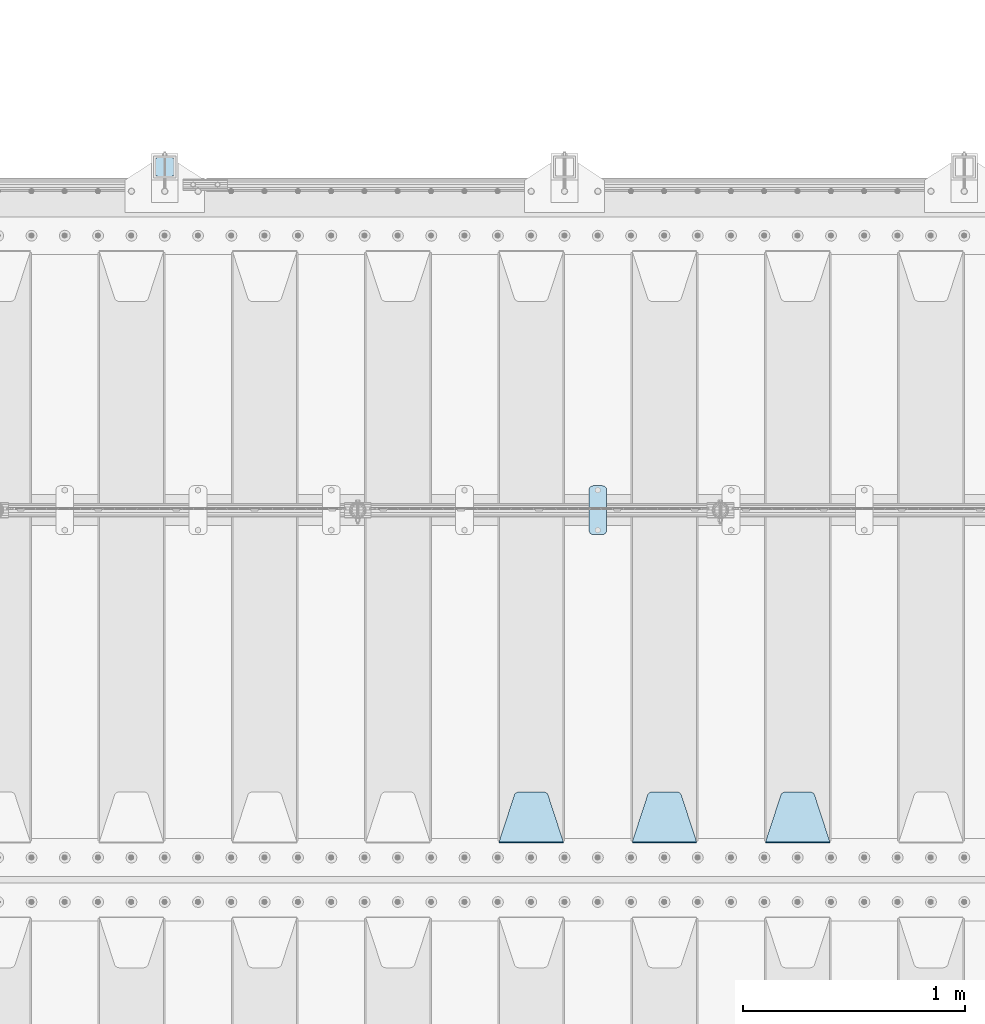
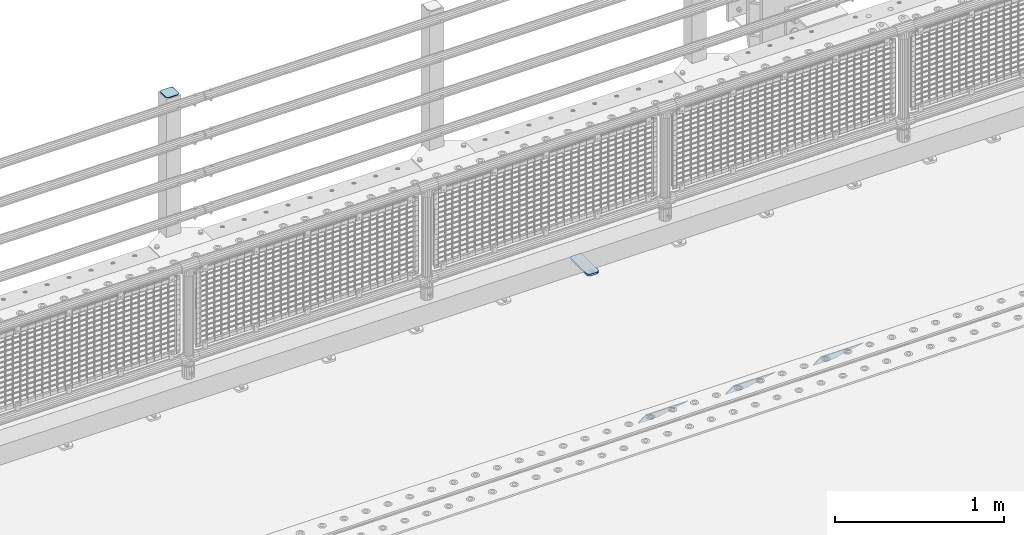
# One storey, part 213 of 242: 5 plates.
"""IFC2X3 building model written with IfcOpenShell, lengths in millimetres."""

from ifc_helpers import new_model, si_unit, frame, origin_with_axes, place, context, subcontext, project, spatial, faceted_brep, material, type_object, element, save


model = new_model("IFC2X3")

# Units and contexts
model_context = context("Model", 3, precision=1e-05, world=origin_with_axes())
body_context = subcontext(model_context, "Body", "Model", "MODEL_VIEW")
ifc_project = project(units=[si_unit("LENGTHUNIT", "METRE", prefix="MILLI"), si_unit("AREAUNIT", "SQUARE_METRE"), si_unit("VOLUMEUNIT", "CUBIC_METRE"), si_unit("MASSUNIT", "GRAM", prefix="KILO"), si_unit("TIMEUNIT", "SECOND"), si_unit("PLANEANGLEUNIT", "RADIAN"), si_unit("SOLIDANGLEUNIT", "STERADIAN"), si_unit("THERMODYNAMICTEMPERATUREUNIT", "DEGREE_CELSIUS"), si_unit("LUMINOUSINTENSITYUNIT", "LUMEN")], contexts=[model_context])

# Site, building, storey
site_placement = place(None, origin_with_axes())
site = spatial("IfcSite", under=ifc_project, at=site_placement, CompositionType="ELEMENT")
building_placement = place(site_placement, origin_with_axes())
building = spatial("IfcBuilding", under=site, at=building_placement, Name="Standard", CompositionType="ELEMENT")
storey_placement = place(building_placement, origin_with_axes())
storey = spatial("IfcBuildingStorey", under=building, at=storey_placement, Name="Undefined", CompositionType="ELEMENT", Elevation=0.0)

# Plates
ifc_material_1 = material(Name="STEEL/S355J2")
plate_type_1 = type_object("IfcPlateType", PredefinedType="NOTDEFINED")
plate_1_placement = place(storey_placement, frame((-30990.0, -19225.5, 21.0199999999977), z_axis=(1.0, 0.0, 0.0), x_axis=(0.0, -1.0, 0.0)))
element("IfcPlate", 1, at=plate_1_placement, inside=storey, type_object=plate_type_1, material=ifc_material_1, context=body_context, shape_type="Brep", body=[
    faceted_brep([(0.0, -7.0, 20.0), (0.0, -7.0, 60.0), (0.0, 7.0, 60.0), (0.0, 7.0, 20.0), (0.384294391937146, -7.0, 63.9018064403208), (0.384294391937146, 7.0, 63.9018064403208), (1.52240934977453, -7.0, 67.6536686473009), (1.52240934977453, 7.0, 67.6536686473009), (3.37060775395003, -7.0, 71.1114046603907), (3.37060775395003, 7.0, 71.1114046603907), (5.8578643762703, -7.0, 74.1421356237297), (5.8578643762703, 7.0, 74.1421356237297), (8.88859533960931, -7.0, 76.62939224605), (8.88859533960931, 7.0, 76.62939224605), (12.3463313526991, -7.0, 78.4775906502255), (12.3463313526991, 7.0, 78.4775906502255), (16.0981935596792, -7.0, 79.6157056080629), (16.0981935596792, 7.0, 79.6157056080629), (20.0, -7.0, 80.0), (20.0, 7.0, 80.0), (200.0, -7.0, 80.0), (200.0, 7.0, 80.0), (203.901806440321, -7.0, 79.6157056080629), (203.901806440321, 7.0, 79.6157056080629), (207.653668647301, -7.0, 78.4775906502255), (207.653668647301, 7.0, 78.4775906502255), (211.111404660391, -7.0, 76.62939224605), (211.111404660391, 7.0, 76.62939224605), (214.14213562373, -7.0, 74.1421356237297), (214.14213562373, 7.0, 74.1421356237297), (216.62939224605, -7.0, 71.1114046603907), (216.62939224605, 7.0, 71.1114046603907), (218.477590650225, -7.0, 67.6536686473009), (218.477590650225, 7.0, 67.6536686473009), (219.615705608063, -7.0, 63.9018064403208), (219.615705608063, 7.0, 63.9018064403208), (220.0, -7.0, 60.0), (220.0, 7.0, 60.0), (220.0, -7.0, 20.0), (220.0, 7.0, 20.0), (219.615705608063, -7.0, 16.0981935596792), (219.615705608063, 7.0, 16.0981935596792), (218.477590650225, -7.0, 12.3463313526991), (218.477590650225, 7.0, 12.3463313526991), (216.62939224605, -7.0, 8.88859533960931), (216.62939224605, 7.0, 8.88859533960931), (214.14213562373, -7.0, 5.8578643762703), (214.14213562373, 7.0, 5.8578643762703), (211.111404660391, -7.0, 3.37060775395003), (211.111404660391, 7.0, 3.37060775395003), (207.653668647301, -7.0, 1.52240934977453), (207.653668647301, 7.0, 1.52240934977453), (203.901806440321, -7.0, 0.384294391937146), (203.901806440321, 7.0, 0.384294391937146), (200.0, -7.0, 0.0), (200.0, 7.0, 0.0), (20.0, -7.0, 0.0), (20.0, 7.0, 0.0), (16.0981935596792, -7.0, 0.384294391937146), (16.0981935596792, 7.0, 0.384294391937146), (12.3463313526991, -7.0, 1.52240934977453), (12.3463313526991, 7.0, 1.52240934977453), (8.88859533960931, -7.0, 3.37060775395003), (8.88859533960931, 7.0, 3.37060775395003), (5.8578643762703, -7.0, 5.8578643762703), (5.8578643762703, 7.0, 5.8578643762703), (3.37060775395003, -7.0, 8.88859533960931), (3.37060775395003, 7.0, 8.88859533960931), (1.52240934977453, -7.0, 12.3463313526991), (1.52240934977453, 7.0, 12.3463313526991), (0.384294391937146, -7.0, 16.0981935596792), (0.384294391937146, 7.0, 16.0981935596792)], [[[0, 1, 2, 3]], [[1, 4, 5, 2]], [[4, 6, 7, 5]], [[6, 8, 9, 7]], [[8, 10, 11, 9]], [[10, 12, 13, 11]], [[12, 14, 15, 13]], [[14, 16, 17, 15]], [[16, 18, 19, 17]], [[18, 20, 21, 19]], [[20, 22, 23, 21]], [[22, 24, 25, 23]], [[24, 26, 27, 25]], [[26, 28, 29, 27]], [[28, 30, 31, 29]], [[30, 32, 33, 31]], [[32, 34, 35, 33]], [[34, 36, 37, 35]], [[36, 38, 39, 37]], [[38, 40, 41, 39]], [[40, 42, 43, 41]], [[42, 44, 45, 43]], [[44, 46, 47, 45]], [[46, 48, 49, 47]], [[48, 50, 51, 49]], [[50, 52, 53, 51]], [[52, 54, 55, 53]], [[54, 56, 57, 55]], [[56, 58, 59, 57]], [[58, 60, 61, 59]], [[60, 62, 63, 61]], [[62, 64, 65, 63]], [[64, 66, 67, 65]], [[66, 68, 69, 67]], [[68, 70, 71, 69]], [[70, 0, 3, 71]], [[5, 7, 9, 11, 13, 15, 17, 19, 21, 23, 25, 27, 29, 31, 33, 35, 37, 39, 41, 43, 45, 47, 49, 51, 53, 55, 57, 59, 61, 63, 65, 67, 69, 71, 3, 2]], [[70, 68, 66, 64, 62, 60, 58, 56, 54, 52, 50, 48, 46, 44, 42, 40, 38, 36, 34, 32, 30, 28, 26, 24, 22, 20, 18, 16, 14, 12, 10, 8, 6, 4, 1, 0]]]),
])
plate_type_2 = type_object("IfcPlateType", PredefinedType="NOTDEFINED")
plate_2_placement = place(storey_placement, frame((-32855.9999999999, -17833.9999999998, 1012.50000000001), z_axis=(0.0, 1.0, 0.0), x_axis=(-1.0, 0.0, 0.0)))
element("IfcPlate", 2, at=plate_2_placement, inside=storey, type_object=plate_type_2, material=ifc_material_1, context=body_context, shape_type="Brep", body=[
    faceted_brep([(0.0, -2.5, 19.0), (0.0, -2.5, 69.0), (0.0, 2.5, 69.0), (0.0, 2.5, 19.0), (0.476369668544066, -2.5, 73.2278977451715), (0.476369668544066, 2.5, 73.2278977451715), (1.88159150985302, -2.5, 77.2437910432345), (1.88159150985302, 2.5, 77.2437910432345), (4.14520183310742, -2.5, 80.8463062353148), (4.14520183310742, 2.5, 80.8463062353148), (7.15369376468516, -2.5, 83.8547981668926), (7.15369376468516, 2.5, 83.8547981668926), (10.7562089567655, -2.5, 86.118408490147), (10.7562089567655, 2.5, 86.118408490147), (14.7721022548285, -2.5, 87.5236303314559), (14.7721022548285, 2.5, 87.5236303314559), (19.0, -2.5, 88.0), (19.0, 2.5, 88.0), (69.0, -2.5, 88.0), (69.0, 2.5, 88.0), (73.2278977451715, -2.5, 87.5236303314559), (73.2278977451715, 2.5, 87.5236303314559), (77.2437910432345, -2.5, 86.118408490147), (77.2437910432345, 2.5, 86.118408490147), (80.8463062353148, -2.5, 83.8547981668926), (80.8463062353148, 2.5, 83.8547981668926), (83.8547981668926, -2.5, 80.8463062353148), (83.8547981668926, 2.5, 80.8463062353148), (86.118408490147, -2.5, 77.2437910432345), (86.118408490147, 2.5, 77.2437910432345), (87.5236303314559, -2.5, 73.2278977451715), (87.5236303314559, 2.5, 73.2278977451715), (88.0, -2.5, 69.0), (88.0, 2.5, 69.0), (88.0, -2.5, 19.0), (88.0, 2.5, 19.0), (87.5236303314559, -2.5, 14.7721022548285), (87.5236303314559, 2.5, 14.7721022548285), (86.118408490147, -2.5, 10.7562089567655), (86.118408490147, 2.5, 10.7562089567655), (83.8547981668926, -2.5, 7.15369376468516), (83.8547981668926, 2.5, 7.15369376468516), (80.8463062353148, -2.5, 4.14520183310742), (80.8463062353148, 2.5, 4.14520183310742), (77.2437910432345, -2.5, 1.88159150985302), (77.2437910432345, 2.5, 1.88159150985302), (73.2278977451715, -2.5, 0.476369668544066), (73.2278977451715, 2.5, 0.476369668544066), (69.0, -2.5, 0.0), (69.0, 2.5, 0.0), (19.0, -2.5, 0.0), (19.0, 2.5, 0.0), (14.7721022548285, -2.5, 0.476369668544066), (14.7721022548285, 2.5, 0.476369668544066), (10.7562089567655, -2.5, 1.88159150985302), (10.7562089567655, 2.5, 1.88159150985302), (7.15369376468516, -2.5, 4.14520183310742), (7.15369376468516, 2.5, 4.14520183310742), (4.14520183310742, -2.5, 7.15369376468516), (4.14520183310742, 2.5, 7.15369376468516), (1.88159150985302, -2.5, 10.7562089567655), (1.88159150985302, 2.5, 10.7562089567655), (0.476369668544066, -2.5, 14.7721022548285), (0.476369668544066, 2.5, 14.7721022548285)], [[[0, 1, 2, 3]], [[1, 4, 5, 2]], [[4, 6, 7, 5]], [[6, 8, 9, 7]], [[8, 10, 11, 9]], [[10, 12, 13, 11]], [[12, 14, 15, 13]], [[14, 16, 17, 15]], [[16, 18, 19, 17]], [[18, 20, 21, 19]], [[20, 22, 23, 21]], [[22, 24, 25, 23]], [[24, 26, 27, 25]], [[26, 28, 29, 27]], [[28, 30, 31, 29]], [[30, 32, 33, 31]], [[32, 34, 35, 33]], [[34, 36, 37, 35]], [[36, 38, 39, 37]], [[38, 40, 41, 39]], [[40, 42, 43, 41]], [[42, 44, 45, 43]], [[44, 46, 47, 45]], [[46, 48, 49, 47]], [[48, 50, 51, 49]], [[50, 52, 53, 51]], [[52, 54, 55, 53]], [[54, 56, 57, 55]], [[56, 58, 59, 57]], [[58, 60, 61, 59]], [[60, 62, 63, 61]], [[62, 0, 3, 63]], [[5, 7, 9, 11, 13, 15, 17, 19, 21, 23, 25, 27, 29, 31, 33, 35, 37, 39, 41, 43, 45, 47, 49, 51, 53, 55, 57, 59, 61, 63, 3, 2]], [[62, 60, 58, 56, 54, 52, 50, 48, 46, 44, 42, 40, 38, 36, 34, 32, 30, 28, 26, 24, 22, 20, 18, 16, 14, 12, 10, 8, 6, 4, 1, 0]]]),
])
ifc_material_2 = material(Name="STEEL/S355N")
plate_type_3 = type_object("IfcPlateType", PredefinedType="NOTDEFINED")
plate_3_placement = place(storey_placement, frame((-29905.0, -20831.767766953, -1.76776695296758), z_axis=(0.0, 0.707106781186547, -0.707106781186548), x_axis=(-1.0, 0.0, 0.0)))
element("IfcPlate", 3, at=plate_3_placement, inside=storey, type_object=plate_type_3, material=ifc_material_2, context=body_context, shape_type="Brep", body=[
    faceted_brep([(0.0, -2.5, 0.0), (69.345504679477, -2.50000000000182, 300.171731424829), (69.345504679477, 2.5, 300.171731424829), (0.0, 2.5, 0.0), (70.9274061199576, -2.5, 304.897442415398), (70.9274061199576, 2.5, 304.897442415398), (73.3818627772307, -2.5, 309.234538108525), (73.3818627772307, 2.50000000000182, 309.234538108529), (76.6187032999551, -2.5, 313.023683126101), (76.6187032999551, 2.50000000000182, 313.023683126103), (80.5190132704993, -2.5, 316.12567259537), (80.5190132704993, 2.5, 316.12567259537), (84.9395038596849, -2.5, 318.426546230474), (84.9395038596849, 2.50000000000182, 318.426546230476), (89.7177759439219, -2.49999999999818, 319.841774983273), (89.7177759439219, 2.50000000000182, 319.841774983273), (94.678286292652, -2.5, 320.319366455076), (94.678286292652, 2.5, 320.319366455076), (195.321713707348, -2.5, 320.319366455076), (195.321713707348, 2.5, 320.319366455076), (200.282224056078, -2.5, 319.841774983272), (200.282224056078, 2.50000000000182, 319.841774983273), (205.060496140315, -2.5, 318.426546230474), (205.060496140315, 2.49999999999818, 318.426546230474), (209.480986729501, -2.49999999999818, 316.12567259537), (209.480986729501, 2.5, 316.12567259537), (213.381296700045, -2.5, 313.023683126101), (213.381296700045, 2.49999999999818, 313.023683126101), (216.618137222769, -2.5, 309.234538108525), (216.618137222769, 2.5, 309.234538108523), (219.072593880042, -2.49999999999818, 304.897442415398), (219.072593880042, 2.50000000000182, 304.897442415398), (220.654495320523, -2.50000000000182, 300.171731424829), (220.654495320523, 2.5, 300.171731424829), (290.0, -2.5, 0.0), (290.0, 2.5, -1.81898940354586e-12)], [[[0, 1, 2, 3]], [[1, 4, 5, 2]], [[4, 6, 7, 5]], [[6, 8, 9, 7]], [[8, 10, 11, 9]], [[10, 12, 13, 11]], [[12, 14, 15, 13]], [[14, 16, 17, 15]], [[16, 18, 19, 17]], [[18, 20, 21, 19]], [[20, 22, 23, 21]], [[22, 24, 25, 23]], [[24, 26, 27, 25]], [[26, 28, 29, 27]], [[28, 30, 31, 29]], [[30, 32, 33, 31]], [[32, 34, 35, 33]], [[34, 0, 3, 35]], [[5, 7, 9, 11, 13, 15, 17, 19, 21, 23, 25, 27, 29, 31, 33, 35, 3, 2]], [[34, 32, 30, 28, 26, 24, 22, 20, 18, 16, 14, 12, 10, 8, 6, 4, 1, 0]]]),
])
plate_4_placement = place(storey_placement, frame((-30505.0, -20831.767766953, -1.76776695296758), z_axis=(0.0, 0.707106781186547, -0.707106781186548), x_axis=(-1.0, 0.0, 0.0)))
element("IfcPlate", 4, at=plate_4_placement, inside=storey, type_object=plate_type_3, material=ifc_material_2, context=body_context, shape_type="Brep", body=[
    faceted_brep([(0.0, -2.5, 0.0), (69.345504679477, -2.50000000000182, 300.171731424829), (69.345504679477, 2.5, 300.171731424829), (0.0, 2.5, 0.0), (70.9274061199576, -2.5, 304.897442415398), (70.9274061199576, 2.5, 304.897442415398), (73.3818627772307, -2.5, 309.234538108525), (73.3818627772307, 2.50000000000182, 309.234538108529), (76.6187032999551, -2.5, 313.023683126101), (76.6187032999551, 2.50000000000182, 313.023683126103), (80.5190132704993, -2.5, 316.12567259537), (80.5190132704993, 2.5, 316.12567259537), (84.9395038596849, -2.5, 318.426546230474), (84.9395038596849, 2.50000000000182, 318.426546230476), (89.7177759439219, -2.49999999999818, 319.841774983273), (89.7177759439219, 2.50000000000182, 319.841774983273), (94.678286292652, -2.5, 320.319366455076), (94.678286292652, 2.5, 320.319366455076), (195.321713707348, -2.5, 320.319366455076), (195.321713707348, 2.5, 320.319366455076), (200.282224056078, -2.5, 319.841774983272), (200.282224056078, 2.50000000000182, 319.841774983273), (205.060496140315, -2.5, 318.426546230474), (205.060496140315, 2.49999999999818, 318.426546230474), (209.480986729501, -2.49999999999818, 316.12567259537), (209.480986729501, 2.5, 316.12567259537), (213.381296700045, -2.5, 313.023683126101), (213.381296700045, 2.49999999999818, 313.023683126101), (216.618137222769, -2.5, 309.234538108525), (216.618137222769, 2.5, 309.234538108523), (219.072593880042, -2.49999999999818, 304.897442415398), (219.072593880042, 2.50000000000182, 304.897442415398), (220.654495320523, -2.50000000000182, 300.171731424829), (220.654495320523, 2.5, 300.171731424829), (290.0, -2.5, 0.0), (290.0, 2.5, -1.81898940354586e-12)], [[[0, 1, 2, 3]], [[1, 4, 5, 2]], [[4, 6, 7, 5]], [[6, 8, 9, 7]], [[8, 10, 11, 9]], [[10, 12, 13, 11]], [[12, 14, 15, 13]], [[14, 16, 17, 15]], [[16, 18, 19, 17]], [[18, 20, 21, 19]], [[20, 22, 23, 21]], [[22, 24, 25, 23]], [[24, 26, 27, 25]], [[26, 28, 29, 27]], [[28, 30, 31, 29]], [[30, 32, 33, 31]], [[32, 34, 35, 33]], [[34, 0, 3, 35]], [[5, 7, 9, 11, 13, 15, 17, 19, 21, 23, 25, 27, 29, 31, 33, 35, 3, 2]], [[34, 32, 30, 28, 26, 24, 22, 20, 18, 16, 14, 12, 10, 8, 6, 4, 1, 0]]]),
])
plate_5_placement = place(storey_placement, frame((-31105.0, -20831.767766953, -1.76776695296758), z_axis=(0.0, 0.707106781186547, -0.707106781186548), x_axis=(-1.0, 0.0, 0.0)))
element("IfcPlate", 5, at=plate_5_placement, inside=storey, type_object=plate_type_3, material=ifc_material_2, context=body_context, shape_type="Brep", body=[
    faceted_brep([(0.0, -2.5, 0.0), (69.345504679477, -2.50000000000182, 300.171731424829), (69.345504679477, 2.5, 300.171731424829), (0.0, 2.5, 0.0), (70.9274061199576, -2.5, 304.897442415398), (70.9274061199576, 2.5, 304.897442415398), (73.3818627772307, -2.5, 309.234538108525), (73.3818627772307, 2.50000000000182, 309.234538108529), (76.6187032999551, -2.5, 313.023683126101), (76.6187032999551, 2.50000000000182, 313.023683126103), (80.5190132704993, -2.5, 316.12567259537), (80.5190132704993, 2.5, 316.12567259537), (84.9395038596849, -2.5, 318.426546230474), (84.9395038596849, 2.50000000000182, 318.426546230476), (89.7177759439219, -2.49999999999818, 319.841774983273), (89.7177759439219, 2.50000000000182, 319.841774983273), (94.678286292652, -2.5, 320.319366455076), (94.678286292652, 2.5, 320.319366455076), (195.321713707348, -2.5, 320.319366455076), (195.321713707348, 2.5, 320.319366455076), (200.282224056078, -2.5, 319.841774983272), (200.282224056078, 2.50000000000182, 319.841774983273), (205.060496140315, -2.5, 318.426546230474), (205.060496140315, 2.49999999999818, 318.426546230474), (209.480986729501, -2.49999999999818, 316.12567259537), (209.480986729501, 2.5, 316.12567259537), (213.381296700045, -2.5, 313.023683126101), (213.381296700045, 2.49999999999818, 313.023683126101), (216.618137222769, -2.5, 309.234538108525), (216.618137222769, 2.5, 309.234538108523), (219.072593880042, -2.49999999999818, 304.897442415398), (219.072593880042, 2.50000000000182, 304.897442415398), (220.654495320523, -2.50000000000182, 300.171731424829), (220.654495320523, 2.5, 300.171731424829), (290.0, -2.5, 0.0), (290.0, 2.5, -1.81898940354586e-12)], [[[0, 1, 2, 3]], [[1, 4, 5, 2]], [[4, 6, 7, 5]], [[6, 8, 9, 7]], [[8, 10, 11, 9]], [[10, 12, 13, 11]], [[12, 14, 15, 13]], [[14, 16, 17, 15]], [[16, 18, 19, 17]], [[18, 20, 21, 19]], [[20, 22, 23, 21]], [[22, 24, 25, 23]], [[24, 26, 27, 25]], [[26, 28, 29, 27]], [[28, 30, 31, 29]], [[30, 32, 33, 31]], [[32, 34, 35, 33]], [[34, 0, 3, 35]], [[5, 7, 9, 11, 13, 15, 17, 19, 21, 23, 25, 27, 29, 31, 33, 35, 3, 2]], [[34, 32, 30, 28, 26, 24, 22, 20, 18, 16, 14, 12, 10, 8, 6, 4, 1, 0]]]),
])

save(model, "model.ifc")
